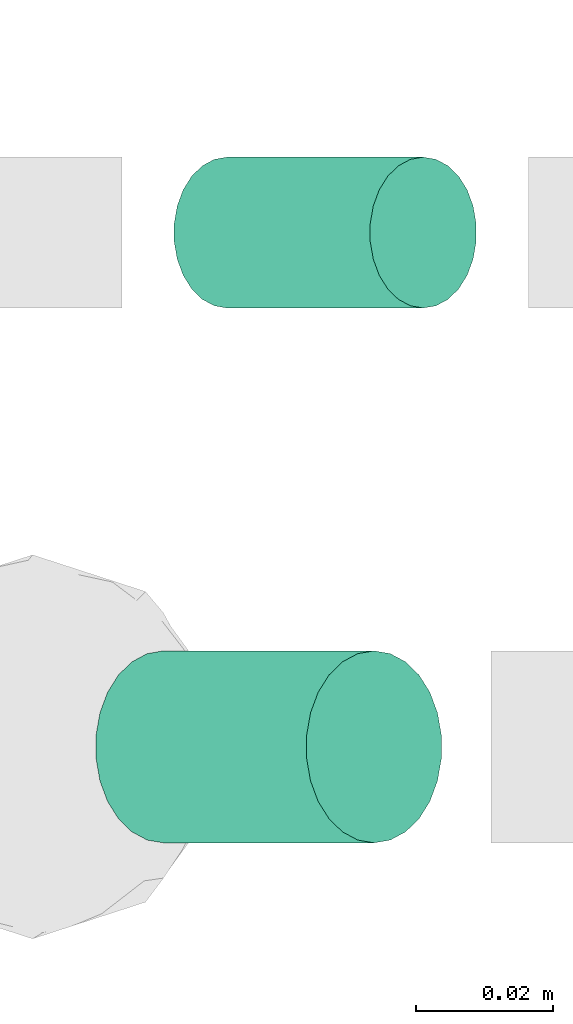
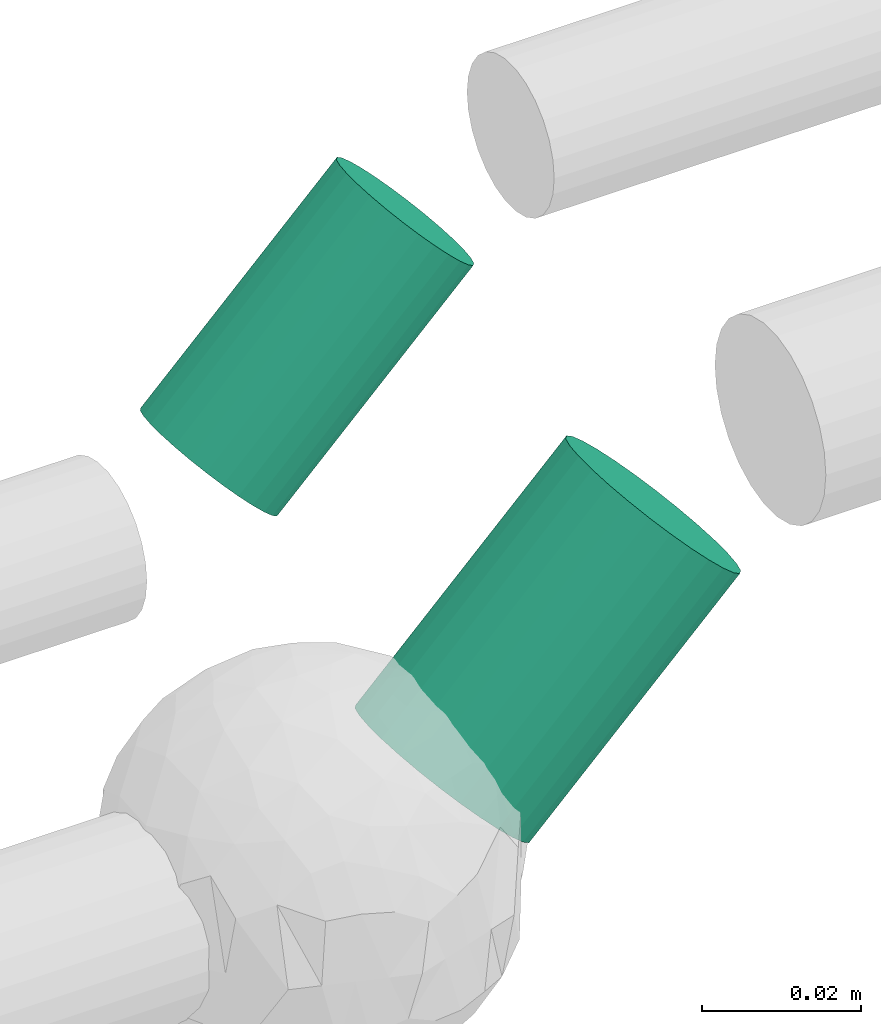
# One storey, part 252 of 331: 2 flow segments.
"""IFC2X3 building model written with IfcOpenShell, lengths in millimetres."""

from ifc_helpers import new_model, entity, si_unit, converted_unit, derived_unit, direction, frame, origin, origin_2d_with_axis, place, context, subcontext, project, spatial, circle, extrude, type_object, element, save


model = new_model("IFC2X3")

# Units and contexts
model_context = context("Model", 3, precision=0.01, world=origin(), true_north=direction((6.12303176911189e-17, 1.0)))
body_context = subcontext(model_context, "Body", "Model", "MODEL_VIEW")
ifc_project = project(units=[si_unit("LENGTHUNIT", "METRE", prefix="MILLI"), si_unit("AREAUNIT", "SQUARE_METRE"), si_unit("VOLUMEUNIT", "CUBIC_METRE"), converted_unit("PLANEANGLEUNIT", "DEGREE", entity("IfcRatioMeasure", 0.0174532925199433), si_unit("PLANEANGLEUNIT", "RADIAN"), dimensions=[0, 0, 0, 0, 0, 0, 0]), si_unit("MASSUNIT", "GRAM", prefix="KILO"), derived_unit("MASSDENSITYUNIT", [(si_unit("MASSUNIT", "GRAM", prefix="KILO"), 1), (si_unit("LENGTHUNIT", "METRE"), -3)]), derived_unit("MOMENTOFINERTIAUNIT", [(si_unit("LENGTHUNIT", "METRE"), 4)]), si_unit("TIMEUNIT", "SECOND"), si_unit("FREQUENCYUNIT", "HERTZ"), si_unit("THERMODYNAMICTEMPERATUREUNIT", "DEGREE_CELSIUS"), derived_unit("THERMALTRANSMITTANCEUNIT", [(si_unit("MASSUNIT", "GRAM", prefix="KILO"), 1), (si_unit("THERMODYNAMICTEMPERATUREUNIT", "KELVIN"), -1), (si_unit("TIMEUNIT", "SECOND"), -3)]), derived_unit("VOLUMETRICFLOWRATEUNIT", [(si_unit("LENGTHUNIT", "METRE"), 3), (si_unit("TIMEUNIT", "SECOND"), -1)]), derived_unit("MASSFLOWRATEUNIT", [(si_unit("MASSUNIT", "GRAM", prefix="KILO"), 1), (si_unit("TIMEUNIT", "SECOND"), -1)]), derived_unit("ROTATIONALFREQUENCYUNIT", [(si_unit("TIMEUNIT", "SECOND"), -1)]), si_unit("ELECTRICCURRENTUNIT", "AMPERE"), si_unit("ELECTRICVOLTAGEUNIT", "VOLT"), si_unit("POWERUNIT", "WATT"), si_unit("FORCEUNIT", "NEWTON", prefix="KILO"), si_unit("ILLUMINANCEUNIT", "LUX"), si_unit("LUMINOUSFLUXUNIT", "LUMEN"), si_unit("LUMINOUSINTENSITYUNIT", "CANDELA"), derived_unit("USERDEFINED", [(si_unit("MASSUNIT", "GRAM", prefix="KILO"), -1), (si_unit("LENGTHUNIT", "METRE"), -2), (si_unit("TIMEUNIT", "SECOND"), 3), (si_unit("LUMINOUSFLUXUNIT", "LUMEN"), 1)]), derived_unit("LINEARVELOCITYUNIT", [(si_unit("LENGTHUNIT", "METRE"), 1), (si_unit("TIMEUNIT", "SECOND"), -1)]), si_unit("PRESSUREUNIT", "PASCAL"), derived_unit("USERDEFINED", [(si_unit("LENGTHUNIT", "METRE"), -2), (si_unit("MASSUNIT", "GRAM", prefix="KILO"), 1), (si_unit("TIMEUNIT", "SECOND"), -2)]), derived_unit("LINEARFORCEUNIT", [(si_unit("MASSUNIT", "GRAM", prefix="KILO"), 1), (si_unit("LENGTHUNIT", "METRE"), 1), (si_unit("TIMEUNIT", "SECOND"), -2), (si_unit("LENGTHUNIT", "METRE"), -1)]), derived_unit("PLANARFORCEUNIT", [(si_unit("MASSUNIT", "GRAM", prefix="KILO"), 1), (si_unit("LENGTHUNIT", "METRE"), 1), (si_unit("TIMEUNIT", "SECOND"), -2), (si_unit("LENGTHUNIT", "METRE"), -2)])], contexts=[model_context])

# Site, building, storey
site_placement = place(None, frame((0.0, -0.00077364408347762, 0.0)))
site = spatial("IfcSite", under=ifc_project, at=site_placement, CompositionType="ELEMENT")
building_placement = place(site_placement, origin())
building = spatial("IfcBuilding", under=site, at=building_placement, CompositionType="ELEMENT")
storey_placement = place(building_placement, origin())
storey = spatial("IfcBuildingStorey", under=building, at=storey_placement, CompositionType="ELEMENT", Elevation=0.0)

# Flow segments
pipe_segment_type = type_object("IfcPipeSegmentType", PredefinedType="NOTDEFINED")
flow_segment_1_placement = place(building_placement, frame((20306.2045970157, 9692.47501991276, 2946.99051420168)))
element("IfcFlowSegment", 1, at=flow_segment_1_placement, inside=storey, type_object=pipe_segment_type, context=body_context, shape_type="SweptSolid", body=[
    extrude(circle(Radius=11.0, at=origin_2d_with_axis()), frame((9.37344682897115, 12.5952722359156, 9.37344682896519), z_axis=(0.707106781186233, 0.0, 0.707106781186862), x_axis=(0.0, 1.0, 0.0)), (0.0, 0.0, 1.0), 40.4314575050883),
])
flow_segment_2_placement = place(building_placement, frame((20294.7903833856, 9614.47786230403, 2945.57630064219)))
element("IfcFlowSegment", 2, at=flow_segment_2_placement, inside=storey, type_object=pipe_segment_type, context=body_context, shape_type="SweptSolid", body=[
    extrude(circle(Radius=14.0, at=origin_2d_with_axis()), frame((11.4947671725293, 15.595272235916, 11.4947671725271), z_axis=(0.707106781186485, 0.0, 0.70710678118661), x_axis=(0.0, -1.0, 0.0)), (0.0, 0.0, 1.0), 43.4314575010413),
])

save(model, "model.ifc")
